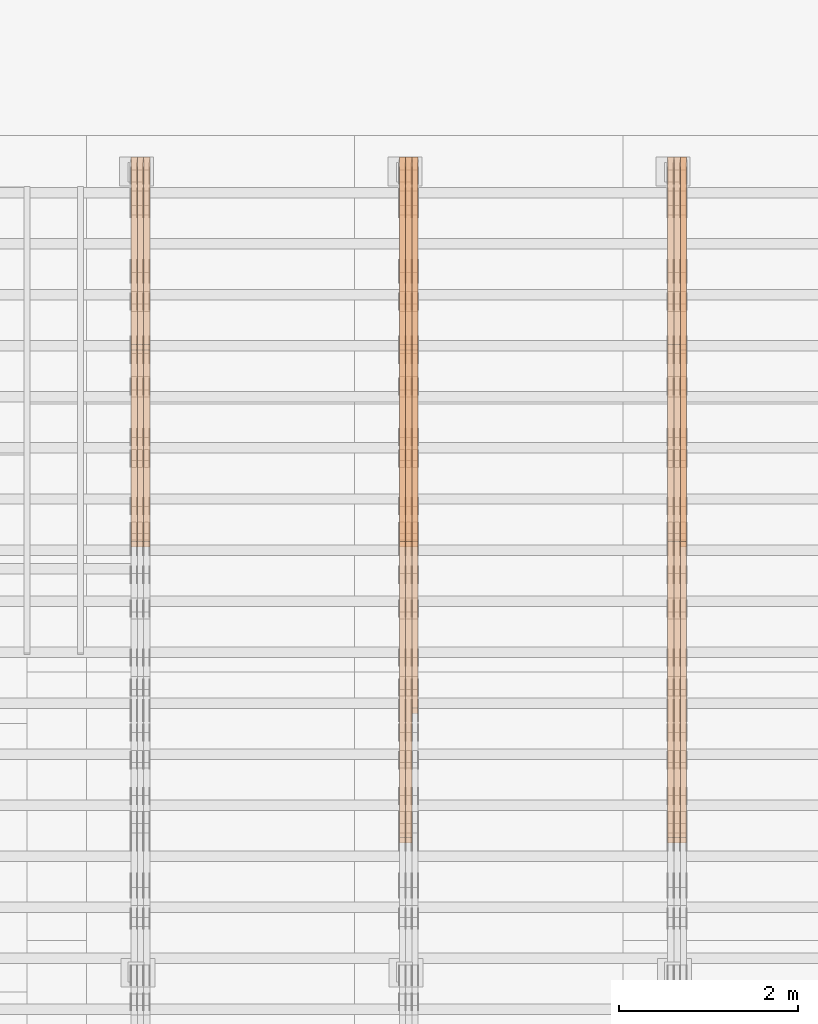
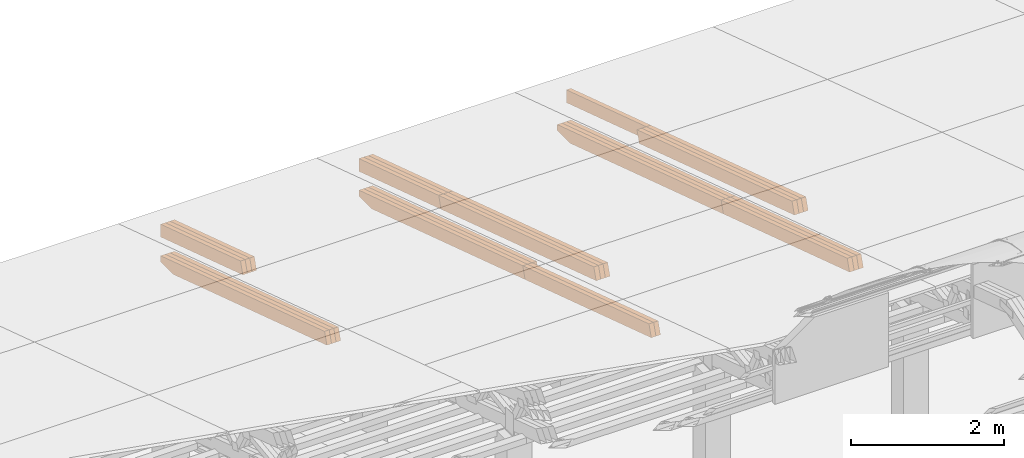
# One storey, part 21 of 385: 27 proxies.
"""IFC2X3 building model written with IfcOpenShell, lengths in millimetres."""

from ifc_helpers import new_model, entity, si_unit, converted_unit, derived_unit, direction, frame, origin, place, context, subcontext, project, spatial, polyline, outline, extrude, source, transform, mapped, material, type_object, type_shapes, element, save


model = new_model("IFC2X3")

# Units and contexts
model_context = context("Model", 3, precision=0.01, world=origin(), true_north=direction((6.12303176911189e-17, 1.0)))
body_context = subcontext(model_context, "Body", "Model", "MODEL_VIEW")
ifc_project = project(units=[si_unit("LENGTHUNIT", "METRE", prefix="MILLI"), si_unit("AREAUNIT", "SQUARE_METRE"), si_unit("VOLUMEUNIT", "CUBIC_METRE"), converted_unit("PLANEANGLEUNIT", "DEGREE", entity("IfcRatioMeasure", 0.0174532925199433), si_unit("PLANEANGLEUNIT", "RADIAN"), dimensions=[0, 0, 0, 0, 0, 0, 0]), si_unit("MASSUNIT", "GRAM", prefix="KILO"), derived_unit("MASSDENSITYUNIT", [(si_unit("MASSUNIT", "GRAM", prefix="KILO"), 1), (si_unit("LENGTHUNIT", "METRE"), -3)]), si_unit("TIMEUNIT", "SECOND"), si_unit("FREQUENCYUNIT", "HERTZ"), si_unit("THERMODYNAMICTEMPERATUREUNIT", "DEGREE_CELSIUS"), derived_unit("THERMALTRANSMITTANCEUNIT", [(si_unit("MASSUNIT", "GRAM", prefix="KILO"), 1), (si_unit("THERMODYNAMICTEMPERATUREUNIT", "KELVIN"), -1), (si_unit("TIMEUNIT", "SECOND"), -3)]), derived_unit("VOLUMETRICFLOWRATEUNIT", [(si_unit("LENGTHUNIT", "METRE"), 3), (si_unit("TIMEUNIT", "SECOND"), -1)]), si_unit("ELECTRICCURRENTUNIT", "AMPERE"), si_unit("ELECTRICVOLTAGEUNIT", "VOLT"), si_unit("POWERUNIT", "WATT"), si_unit("FORCEUNIT", "NEWTON", prefix="KILO"), si_unit("ILLUMINANCEUNIT", "LUX"), si_unit("LUMINOUSFLUXUNIT", "LUMEN"), si_unit("LUMINOUSINTENSITYUNIT", "CANDELA"), derived_unit("USERDEFINED", [(si_unit("MASSUNIT", "GRAM", prefix="KILO"), -1), (si_unit("LENGTHUNIT", "METRE"), -2), (si_unit("TIMEUNIT", "SECOND"), 3), (si_unit("LUMINOUSFLUXUNIT", "LUMEN"), 1)]), derived_unit("LINEARVELOCITYUNIT", [(si_unit("LENGTHUNIT", "METRE"), 1), (si_unit("TIMEUNIT", "SECOND"), -1)]), si_unit("PRESSUREUNIT", "PASCAL"), derived_unit("USERDEFINED", [(si_unit("LENGTHUNIT", "METRE"), -2), (si_unit("MASSUNIT", "GRAM", prefix="KILO"), 1), (si_unit("TIMEUNIT", "SECOND"), -2)])], contexts=[model_context])

# Site, building, storey
site_placement = place(None, origin())
site = spatial("IfcSite", under=ifc_project, at=site_placement, CompositionType="ELEMENT")
building_placement = place(site_placement, origin())
building = spatial("IfcBuilding", under=site, at=building_placement, CompositionType="ELEMENT")
storey_placement = place(building_placement, origin())
storey = spatial("IfcBuildingStorey", under=building, at=storey_placement, Name="Default", CompositionType="ELEMENT", Elevation=0.0)

# Proxies
ifc_material_1 = material(Name="IfcSurfaceStyle #180349")
building_element_proxy_type_1 = type_object("IfcBuildingElementProxyType", Name="T1-T2 180347", PredefinedType="NOTDEFINED", material=ifc_material_1)
shared_shape_1 = source(origin(), body_context, "Body", "SweptSolid", [
    extrude(outline(polyline([(-2137.04373183812, -97.5000250291418), (2137.04394104036, -97.5000250291418), (2137.04396402965, 97.5000250291418), (-2137.04417323189, 97.5000250291418), (-2137.04373183812, -97.5000250291418)])), frame((2137.04396402965, 97.5001541485632, 0.0), z_axis=(0.0, 0.0, 1.0), x_axis=(-1.0, 0.0, 0.0)), (0.0, 0.0, 1.0), 69.9999999999997),
])
type_shapes(building_element_proxy_type_1, [shared_shape_1])
proxy_1_placement = place(building_placement, frame((15385.0, 24344.7841397874, 1095.2368156767), z_axis=(-1.0, 0.0, 0.0), x_axis=(0.0, -0.951056516295154, 0.309016994374948)))
element("IfcBuildingElementProxy", 1, at=proxy_1_placement, inside=storey, type_object=building_element_proxy_type_1, material=ifc_material_1, Name="T1-T2", context=body_context, shape_type="MappedRepresentation", body=[
    mapped(shared_shape_1, transform((0.0, 0.0, 0.0), scale=1.0)),
])
ifc_material_2 = material(Name="IfcSurfaceStyle #180292")
building_element_proxy_type_2 = type_object("IfcBuildingElementProxyType", Name="T1-T2 180290", PredefinedType="NOTDEFINED", material=ifc_material_2)
shared_shape_2 = source(origin(), body_context, "Body", "SweptSolid", [
    extrude(outline(polyline([(-2137.04373183812, -97.5000250291418), (2137.04394104036, -97.5000250291418), (2137.04396402965, 97.5000250291418), (-2137.04417323189, 97.5000250291418), (-2137.04373183812, -97.5000250291418)])), frame((2137.04396402965, 97.5001541485632, 0.0), z_axis=(0.0, 0.0, 1.0), x_axis=(-1.0, 0.0, 0.0)), (0.0, 0.0, 1.0), 69.9999999999997),
])
type_shapes(building_element_proxy_type_2, [shared_shape_2])
proxy_2_placement = place(building_placement, frame((15315.0, 24344.7841397874, 1095.2368156767), z_axis=(-1.0, 0.0, 0.0), x_axis=(0.0, -0.951056516295154, 0.309016994374948)))
element("IfcBuildingElementProxy", 2, at=proxy_2_placement, inside=storey, type_object=building_element_proxy_type_2, material=ifc_material_2, Name="T1-T2", context=body_context, shape_type="MappedRepresentation", body=[
    mapped(shared_shape_2, transform((0.0, 0.0, 0.0), scale=1.0)),
])
ifc_material_3 = material(Name="IfcSurfaceStyle #180235")
building_element_proxy_type_3 = type_object("IfcBuildingElementProxyType", Name="T1-T2 180233", PredefinedType="NOTDEFINED", material=ifc_material_3)
shared_shape_3 = source(origin(), body_context, "Body", "SweptSolid", [
    extrude(outline(polyline([(-2137.04373183812, -97.5000250291418), (2137.04394104036, -97.5000250291418), (2137.04396402965, 97.5000250291418), (-2137.04417323189, 97.5000250291418), (-2137.04373183812, -97.5000250291418)])), frame((2137.04396402965, 97.5001541485632, 0.0), z_axis=(0.0, 0.0, 1.0), x_axis=(-1.0, 0.0, 0.0)), (0.0, 0.0, 1.0), 69.9999999999997),
])
type_shapes(building_element_proxy_type_3, [shared_shape_3])
proxy_3_placement = place(building_placement, frame((15245.0, 24344.7841397874, 1095.2368156767), z_axis=(-1.0, 0.0, 0.0), x_axis=(0.0, -0.951056516295154, 0.309016994374948)))
element("IfcBuildingElementProxy", 3, at=proxy_3_placement, inside=storey, type_object=building_element_proxy_type_3, material=ifc_material_3, Name="T1-T2", context=body_context, shape_type="MappedRepresentation", body=[
    mapped(shared_shape_3, transform((0.0, 0.0, 0.0), scale=1.0)),
])
ifc_material_4 = material(Name="IfcSurfaceStyle #180178")
building_element_proxy_type_4 = type_object("IfcBuildingElementProxyType", Name="T1-T3 180176", PredefinedType="NOTDEFINED", material=ifc_material_4)
shared_shape_4 = source(origin(), body_context, "Body", "SweptSolid", [
    extrude(outline(polyline([(-1117.22419189679, -97.5000115568039), (1085.54451125458, -97.5000115568039), (1148.90384954971, 97.5000115568039), (-1117.2241689075, 97.5000115568039), (-1117.22419189679, -97.5000115568039)])), frame((1148.90385201956, 97.5000191595882, 0.0), z_axis=(0.0, 0.0, 1.0), x_axis=(-1.0, 0.0, 0.0)), (0.0, 0.0, 1.0), 69.9999999999999),
])
type_shapes(building_element_proxy_type_4, [shared_shape_4])
proxy_4_placement = place(building_placement, frame((15385.0, 26500.0, 394.964866273674), z_axis=(-1.0, 0.0, 0.0), x_axis=(0.0, -0.951056516295154, 0.309016994374948)))
element("IfcBuildingElementProxy", 4, at=proxy_4_placement, inside=storey, type_object=building_element_proxy_type_4, material=ifc_material_4, Name="T1-T3", context=body_context, shape_type="MappedRepresentation", body=[
    mapped(shared_shape_4, transform((0.0, 0.0, 0.0), scale=1.0)),
])
ifc_material_5 = material(Name="IfcSurfaceStyle #178954")
building_element_proxy_type_5 = type_object("IfcBuildingElementProxyType", Name="T1-B2 178952", PredefinedType="NOTDEFINED", material=ifc_material_5)
shared_shape_5 = source(origin(), body_context, "Body", "SweptSolid", [
    extrude(outline(polyline([(-1738.61933402934, -97.4999466901035), (1738.6190788485, -97.4999466901035), (1738.6191018378, 97.4999466901035), (-1738.61884665697, 97.4999466901035), (-1738.61933402934, -97.4999466901035)])), frame((1738.6191018378, 97.4999528847471, 0.0), z_axis=(0.0, 0.0, 1.0), x_axis=(-1.0, 0.0, 0.0)), (0.0, 0.0, 1.0), 69.9999999999998),
])
type_shapes(building_element_proxy_type_5, [shared_shape_5])
proxy_5_placement = place(building_placement, frame((15385.0, 22140.4521465233, 1306.03026754604), z_axis=(-1.0, 0.0, 0.0), x_axis=(0.0, -0.951056516295124, 0.309016994375039)))
element("IfcBuildingElementProxy", 5, at=proxy_5_placement, inside=storey, type_object=building_element_proxy_type_5, material=ifc_material_5, Name="T1-B2", context=body_context, shape_type="MappedRepresentation", body=[
    mapped(shared_shape_5, transform((0.0, 0.0, 0.0), scale=1.0)),
])
ifc_material_6 = material(Name="IfcSurfaceStyle #178897")
building_element_proxy_type_6 = type_object("IfcBuildingElementProxyType", Name="T1-B2 178895", PredefinedType="NOTDEFINED", material=ifc_material_6)
shared_shape_6 = source(origin(), body_context, "Body", "SweptSolid", [
    extrude(outline(polyline([(-1738.61933402934, -97.4999466901035), (1738.6190788485, -97.4999466901035), (1738.6191018378, 97.4999466901035), (-1738.61884665697, 97.4999466901035), (-1738.61933402934, -97.4999466901035)])), frame((1738.6191018378, 97.4999528847471, 0.0), z_axis=(0.0, 0.0, 1.0), x_axis=(-1.0, 0.0, 0.0)), (0.0, 0.0, 1.0), 69.9999999999998),
])
type_shapes(building_element_proxy_type_6, [shared_shape_6])
proxy_6_placement = place(building_placement, frame((15315.0, 22140.4521465233, 1306.03026754604), z_axis=(-1.0, 0.0, 0.0), x_axis=(0.0, -0.951056516295124, 0.309016994375039)))
element("IfcBuildingElementProxy", 6, at=proxy_6_placement, inside=storey, type_object=building_element_proxy_type_6, material=ifc_material_6, Name="T1-B2", context=body_context, shape_type="MappedRepresentation", body=[
    mapped(shared_shape_6, transform((0.0, 0.0, 0.0), scale=1.0)),
])
ifc_material_7 = material(Name="IfcSurfaceStyle #178840")
building_element_proxy_type_7 = type_object("IfcBuildingElementProxyType", Name="T1-B2 178838", PredefinedType="NOTDEFINED", material=ifc_material_7)
shared_shape_7 = source(origin(), body_context, "Body", "SweptSolid", [
    extrude(outline(polyline([(-1738.61933402934, -97.4999466901035), (1738.6190788485, -97.4999466901035), (1738.6191018378, 97.4999466901035), (-1738.61884665697, 97.4999466901035), (-1738.61933402934, -97.4999466901035)])), frame((1738.6191018378, 97.4999528847471, 0.0), z_axis=(0.0, 0.0, 1.0), x_axis=(-1.0, 0.0, 0.0)), (0.0, 0.0, 1.0), 69.9999999999998),
])
type_shapes(building_element_proxy_type_7, [shared_shape_7])
proxy_7_placement = place(building_placement, frame((15245.0, 22140.4521465233, 1306.03026754604), z_axis=(-1.0, 0.0, 0.0), x_axis=(0.0, -0.951056516295124, 0.309016994375039)))
element("IfcBuildingElementProxy", 7, at=proxy_7_placement, inside=storey, type_object=building_element_proxy_type_7, material=ifc_material_7, Name="T1-B2", context=body_context, shape_type="MappedRepresentation", body=[
    mapped(shared_shape_7, transform((0.0, 0.0, 0.0), scale=1.0)),
])
ifc_material_8 = material(Name="IfcSurfaceStyle #178783")
building_element_proxy_type_8 = type_object("IfcBuildingElementProxyType", Name="T1-B1 178781", PredefinedType="NOTDEFINED", material=ifc_material_8)
shared_shape_8 = source(origin(), body_context, "Body", "SweptSolid", [
    extrude(outline(polyline([(-2659.34106034305, -95.9868650736445), (1861.19950396595, -95.9868650736445), (1890.42090463564, -6.05260867570997), (1567.0616890952, 99.0131694114995), (-2659.34103735375, 99.0131694114995), (-2659.34106034305, -95.9868650736445)])), frame((1890.42090463564, 99.013169411504, 0.0), z_axis=(0.0, 0.0, 1.0), x_axis=(-1.0, 0.0, 0.0)), (0.0, 0.0, 1.0), 69.9999999999997),
])
type_shapes(building_element_proxy_type_8, [shared_shape_8])
proxy_8_placement = place(building_placement, frame((15385.0, 26467.5328890438, -99.9234928894624), z_axis=(-1.0, 0.0, 0.0), x_axis=(0.0, -0.951056516295124, 0.309016994375039)))
element("IfcBuildingElementProxy", 8, at=proxy_8_placement, inside=storey, type_object=building_element_proxy_type_8, material=ifc_material_8, Name="T1-B1", context=body_context, shape_type="MappedRepresentation", body=[
    mapped(shared_shape_8, transform((0.0, 0.0, 0.0), scale=1.0)),
])
ifc_material_9 = material(Name="IfcSurfaceStyle #178717")
building_element_proxy_type_9 = type_object("IfcBuildingElementProxyType", Name="T1-B1 178715", PredefinedType="NOTDEFINED", material=ifc_material_9)
shared_shape_9 = source(origin(), body_context, "Body", "SweptSolid", [
    extrude(outline(polyline([(-2659.34106034305, -95.9868650736445), (1861.19950396595, -95.9868650736445), (1890.42090463564, -6.05260867570997), (1567.0616890952, 99.0131694114995), (-2659.34103735375, 99.0131694114995), (-2659.34106034305, -95.9868650736445)])), frame((1890.42090463564, 99.013169411504, 0.0), z_axis=(0.0, 0.0, 1.0), x_axis=(-1.0, 0.0, 0.0)), (0.0, 0.0, 1.0), 69.9999999999997),
])
type_shapes(building_element_proxy_type_9, [shared_shape_9])
proxy_9_placement = place(building_placement, frame((15315.0, 26467.5328890438, -99.9234928894624), z_axis=(-1.0, 0.0, 0.0), x_axis=(0.0, -0.951056516295124, 0.309016994375039)))
element("IfcBuildingElementProxy", 9, at=proxy_9_placement, inside=storey, type_object=building_element_proxy_type_9, material=ifc_material_9, Name="T1-B1", context=body_context, shape_type="MappedRepresentation", body=[
    mapped(shared_shape_9, transform((0.0, 0.0, 0.0), scale=1.0)),
])
ifc_material_10 = material(Name="IfcSurfaceStyle #178651")
building_element_proxy_type_10 = type_object("IfcBuildingElementProxyType", Name="T1-B1 178649", PredefinedType="NOTDEFINED", material=ifc_material_10)
shared_shape_10 = source(origin(), body_context, "Body", "SweptSolid", [
    extrude(outline(polyline([(-2659.34106034305, -95.9868650736445), (1861.19950396595, -95.9868650736445), (1890.42090463564, -6.05260867570997), (1567.0616890952, 99.0131694114995), (-2659.34103735375, 99.0131694114995), (-2659.34106034305, -95.9868650736445)])), frame((1890.42090463564, 99.013169411504, 0.0), z_axis=(0.0, 0.0, 1.0), x_axis=(-1.0, 0.0, 0.0)), (0.0, 0.0, 1.0), 69.9999999999997),
])
type_shapes(building_element_proxy_type_10, [shared_shape_10])
proxy_10_placement = place(building_placement, frame((15245.0, 26467.5328890438, -99.9234928894624), z_axis=(-1.0, 0.0, 0.0), x_axis=(0.0, -0.951056516295124, 0.309016994375039)))
element("IfcBuildingElementProxy", 10, at=proxy_10_placement, inside=storey, type_object=building_element_proxy_type_10, material=ifc_material_10, Name="T1-B1", context=body_context, shape_type="MappedRepresentation", body=[
    mapped(shared_shape_10, transform((0.0, 0.0, 0.0), scale=1.0)),
])
ifc_material_11 = material(Name="IfcSurfaceStyle #145917")
building_element_proxy_type_11 = type_object("IfcBuildingElementProxyType", Name="T1-T2 145915", PredefinedType="NOTDEFINED", material=ifc_material_11)
shared_shape_11 = source(origin(), body_context, "Body", "SweptSolid", [
    extrude(outline(polyline([(-2137.04373183812, -97.5000250291418), (2137.04394104036, -97.5000250291418), (2137.04396402965, 97.5000250291418), (-2137.04417323189, 97.5000250291418), (-2137.04373183812, -97.5000250291418)])), frame((2137.04396402965, 97.5001541485632, 0.0), z_axis=(0.0, 0.0, 1.0), x_axis=(-1.0, 0.0, 0.0)), (0.0, 0.0, 1.0), 69.9999999999997),
])
type_shapes(building_element_proxy_type_11, [shared_shape_11])
proxy_11_placement = place(building_placement, frame((12385.0, 24344.7841397874, 1095.2368156767), z_axis=(-1.0, 0.0, 0.0), x_axis=(0.0, -0.951056516295154, 0.309016994374948)))
element("IfcBuildingElementProxy", 11, at=proxy_11_placement, inside=storey, type_object=building_element_proxy_type_11, material=ifc_material_11, Name="T1-T2", context=body_context, shape_type="MappedRepresentation", body=[
    mapped(shared_shape_11, transform((0.0, 0.0, 0.0), scale=1.0)),
])
ifc_material_12 = material(Name="IfcSurfaceStyle #145860")
building_element_proxy_type_12 = type_object("IfcBuildingElementProxyType", Name="T1-T2 145858", PredefinedType="NOTDEFINED", material=ifc_material_12)
shared_shape_12 = source(origin(), body_context, "Body", "SweptSolid", [
    extrude(outline(polyline([(-2137.04373183812, -97.5000250291418), (2137.04394104036, -97.5000250291418), (2137.04396402965, 97.5000250291418), (-2137.04417323189, 97.5000250291418), (-2137.04373183812, -97.5000250291418)])), frame((2137.04396402965, 97.5001541485632, 0.0), z_axis=(0.0, 0.0, 1.0), x_axis=(-1.0, 0.0, 0.0)), (0.0, 0.0, 1.0), 69.9999999999997),
])
type_shapes(building_element_proxy_type_12, [shared_shape_12])
proxy_12_placement = place(building_placement, frame((12315.0, 24344.7841397874, 1095.2368156767), z_axis=(-1.0, 0.0, 0.0), x_axis=(0.0, -0.951056516295154, 0.309016994374948)))
element("IfcBuildingElementProxy", 12, at=proxy_12_placement, inside=storey, type_object=building_element_proxy_type_12, material=ifc_material_12, Name="T1-T2", context=body_context, shape_type="MappedRepresentation", body=[
    mapped(shared_shape_12, transform((0.0, 0.0, 0.0), scale=1.0)),
])
ifc_material_13 = material(Name="IfcSurfaceStyle #145803")
building_element_proxy_type_13 = type_object("IfcBuildingElementProxyType", Name="T1-T2 145801", PredefinedType="NOTDEFINED", material=ifc_material_13)
shared_shape_13 = source(origin(), body_context, "Body", "SweptSolid", [
    extrude(outline(polyline([(-2137.04373183812, -97.5000250291418), (2137.04394104036, -97.5000250291418), (2137.04396402965, 97.5000250291418), (-2137.04417323189, 97.5000250291418), (-2137.04373183812, -97.5000250291418)])), frame((2137.04396402965, 97.5001541485632, 0.0), z_axis=(0.0, 0.0, 1.0), x_axis=(-1.0, 0.0, 0.0)), (0.0, 0.0, 1.0), 69.9999999999997),
])
type_shapes(building_element_proxy_type_13, [shared_shape_13])
proxy_13_placement = place(building_placement, frame((12245.0, 24344.7841397874, 1095.2368156767), z_axis=(-1.0, 0.0, 0.0), x_axis=(0.0, -0.951056516295154, 0.309016994374948)))
element("IfcBuildingElementProxy", 13, at=proxy_13_placement, inside=storey, type_object=building_element_proxy_type_13, material=ifc_material_13, Name="T1-T2", context=body_context, shape_type="MappedRepresentation", body=[
    mapped(shared_shape_13, transform((0.0, 0.0, 0.0), scale=1.0)),
])
ifc_material_14 = material(Name="IfcSurfaceStyle #145746")
building_element_proxy_type_14 = type_object("IfcBuildingElementProxyType", Name="T1-T3 145744", PredefinedType="NOTDEFINED", material=ifc_material_14)
shared_shape_14 = source(origin(), body_context, "Body", "SweptSolid", [
    extrude(outline(polyline([(-1117.22419189679, -97.5000115568039), (1085.54451125458, -97.5000115568039), (1148.90384954971, 97.5000115568039), (-1117.2241689075, 97.5000115568039), (-1117.22419189679, -97.5000115568039)])), frame((1148.90385201956, 97.5000191595882, 0.0), z_axis=(0.0, 0.0, 1.0), x_axis=(-1.0, 0.0, 0.0)), (0.0, 0.0, 1.0), 69.9999999999999),
])
type_shapes(building_element_proxy_type_14, [shared_shape_14])
proxy_14_placement = place(building_placement, frame((12385.0, 26500.0, 394.964866273674), z_axis=(-1.0, 0.0, 0.0), x_axis=(0.0, -0.951056516295154, 0.309016994374948)))
element("IfcBuildingElementProxy", 14, at=proxy_14_placement, inside=storey, type_object=building_element_proxy_type_14, material=ifc_material_14, Name="T1-T3", context=body_context, shape_type="MappedRepresentation", body=[
    mapped(shared_shape_14, transform((0.0, 0.0, 0.0), scale=1.0)),
])
ifc_material_15 = material(Name="IfcSurfaceStyle #145689")
building_element_proxy_type_15 = type_object("IfcBuildingElementProxyType", Name="T1-T3 145687", PredefinedType="NOTDEFINED", material=ifc_material_15)
shared_shape_15 = source(origin(), body_context, "Body", "SweptSolid", [
    extrude(outline(polyline([(-1117.22419189679, -97.5000115568039), (1085.54451125458, -97.5000115568039), (1148.90384954971, 97.5000115568039), (-1117.2241689075, 97.5000115568039), (-1117.22419189679, -97.5000115568039)])), frame((1148.90385201956, 97.5000191595882, 0.0), z_axis=(0.0, 0.0, 1.0), x_axis=(-1.0, 0.0, 0.0)), (0.0, 0.0, 1.0), 69.9999999999999),
])
type_shapes(building_element_proxy_type_15, [shared_shape_15])
proxy_15_placement = place(building_placement, frame((12315.0, 26500.0, 394.964866273674), z_axis=(-1.0, 0.0, 0.0), x_axis=(0.0, -0.951056516295154, 0.309016994374948)))
element("IfcBuildingElementProxy", 15, at=proxy_15_placement, inside=storey, type_object=building_element_proxy_type_15, material=ifc_material_15, Name="T1-T3", context=body_context, shape_type="MappedRepresentation", body=[
    mapped(shared_shape_15, transform((0.0, 0.0, 0.0), scale=1.0)),
])
ifc_material_16 = material(Name="IfcSurfaceStyle #145632")
building_element_proxy_type_16 = type_object("IfcBuildingElementProxyType", Name="T1-T3 145630", PredefinedType="NOTDEFINED", material=ifc_material_16)
shared_shape_16 = source(origin(), body_context, "Body", "SweptSolid", [
    extrude(outline(polyline([(-1117.22419189679, -97.5000115568039), (1085.54451125458, -97.5000115568039), (1148.90384954971, 97.5000115568039), (-1117.2241689075, 97.5000115568039), (-1117.22419189679, -97.5000115568039)])), frame((1148.90385201956, 97.5000191595882, 0.0), z_axis=(0.0, 0.0, 1.0), x_axis=(-1.0, 0.0, 0.0)), (0.0, 0.0, 1.0), 69.9999999999999),
])
type_shapes(building_element_proxy_type_16, [shared_shape_16])
proxy_16_placement = place(building_placement, frame((12245.0, 26500.0, 394.964866273674), z_axis=(-1.0, 0.0, 0.0), x_axis=(0.0, -0.951056516295154, 0.309016994374948)))
element("IfcBuildingElementProxy", 16, at=proxy_16_placement, inside=storey, type_object=building_element_proxy_type_16, material=ifc_material_16, Name="T1-T3", context=body_context, shape_type="MappedRepresentation", body=[
    mapped(shared_shape_16, transform((0.0, 0.0, 0.0), scale=1.0)),
])
ifc_material_17 = material(Name="IfcSurfaceStyle #144465")
building_element_proxy_type_17 = type_object("IfcBuildingElementProxyType", Name="T1-B2 144463", PredefinedType="NOTDEFINED", material=ifc_material_17)
shared_shape_17 = source(origin(), body_context, "Body", "SweptSolid", [
    extrude(outline(polyline([(-1738.61933402934, -97.4999466901035), (1738.6190788485, -97.4999466901035), (1738.6191018378, 97.4999466901035), (-1738.61884665697, 97.4999466901035), (-1738.61933402934, -97.4999466901035)])), frame((1738.6191018378, 97.4999528847471, 0.0), z_axis=(0.0, 0.0, 1.0), x_axis=(-1.0, 0.0, 0.0)), (0.0, 0.0, 1.0), 69.9999999999998),
])
type_shapes(building_element_proxy_type_17, [shared_shape_17])
proxy_17_placement = place(building_placement, frame((12315.0, 22140.4521465233, 1306.03026754604), z_axis=(-1.0, 0.0, 0.0), x_axis=(0.0, -0.951056516295124, 0.309016994375039)))
element("IfcBuildingElementProxy", 17, at=proxy_17_placement, inside=storey, type_object=building_element_proxy_type_17, material=ifc_material_17, Name="T1-B2", context=body_context, shape_type="MappedRepresentation", body=[
    mapped(shared_shape_17, transform((0.0, 0.0, 0.0), scale=1.0)),
])
ifc_material_18 = material(Name="IfcSurfaceStyle #144408")
building_element_proxy_type_18 = type_object("IfcBuildingElementProxyType", Name="T1-B2 144406", PredefinedType="NOTDEFINED", material=ifc_material_18)
shared_shape_18 = source(origin(), body_context, "Body", "SweptSolid", [
    extrude(outline(polyline([(-1738.61933402934, -97.4999466901035), (1738.6190788485, -97.4999466901035), (1738.6191018378, 97.4999466901035), (-1738.61884665697, 97.4999466901035), (-1738.61933402934, -97.4999466901035)])), frame((1738.6191018378, 97.4999528847471, 0.0), z_axis=(0.0, 0.0, 1.0), x_axis=(-1.0, 0.0, 0.0)), (0.0, 0.0, 1.0), 69.9999999999998),
])
type_shapes(building_element_proxy_type_18, [shared_shape_18])
proxy_18_placement = place(building_placement, frame((12245.0, 22140.4521465233, 1306.03026754604), z_axis=(-1.0, 0.0, 0.0), x_axis=(0.0, -0.951056516295124, 0.309016994375039)))
element("IfcBuildingElementProxy", 18, at=proxy_18_placement, inside=storey, type_object=building_element_proxy_type_18, material=ifc_material_18, Name="T1-B2", context=body_context, shape_type="MappedRepresentation", body=[
    mapped(shared_shape_18, transform((0.0, 0.0, 0.0), scale=1.0)),
])
ifc_material_19 = material(Name="IfcSurfaceStyle #144351")
building_element_proxy_type_19 = type_object("IfcBuildingElementProxyType", Name="T1-B1 144349", PredefinedType="NOTDEFINED", material=ifc_material_19)
shared_shape_19 = source(origin(), body_context, "Body", "SweptSolid", [
    extrude(outline(polyline([(-2659.34106034305, -95.9868650736445), (1861.19950396595, -95.9868650736445), (1890.42090463564, -6.05260867570997), (1567.0616890952, 99.0131694114995), (-2659.34103735375, 99.0131694114995), (-2659.34106034305, -95.9868650736445)])), frame((1890.42090463564, 99.013169411504, 0.0), z_axis=(0.0, 0.0, 1.0), x_axis=(-1.0, 0.0, 0.0)), (0.0, 0.0, 1.0), 69.9999999999997),
])
type_shapes(building_element_proxy_type_19, [shared_shape_19])
proxy_19_placement = place(building_placement, frame((12385.0, 26467.5328890438, -99.9234928894624), z_axis=(-1.0, 0.0, 0.0), x_axis=(0.0, -0.951056516295124, 0.309016994375039)))
element("IfcBuildingElementProxy", 19, at=proxy_19_placement, inside=storey, type_object=building_element_proxy_type_19, material=ifc_material_19, Name="T1-B1", context=body_context, shape_type="MappedRepresentation", body=[
    mapped(shared_shape_19, transform((0.0, 0.0, 0.0), scale=1.0)),
])
ifc_material_20 = material(Name="IfcSurfaceStyle #144285")
building_element_proxy_type_20 = type_object("IfcBuildingElementProxyType", Name="T1-B1 144283", PredefinedType="NOTDEFINED", material=ifc_material_20)
shared_shape_20 = source(origin(), body_context, "Body", "SweptSolid", [
    extrude(outline(polyline([(-2659.34106034305, -95.9868650736445), (1861.19950396595, -95.9868650736445), (1890.42090463564, -6.05260867570997), (1567.0616890952, 99.0131694114995), (-2659.34103735375, 99.0131694114995), (-2659.34106034305, -95.9868650736445)])), frame((1890.42090463564, 99.013169411504, 0.0), z_axis=(0.0, 0.0, 1.0), x_axis=(-1.0, 0.0, 0.0)), (0.0, 0.0, 1.0), 69.9999999999997),
])
type_shapes(building_element_proxy_type_20, [shared_shape_20])
proxy_20_placement = place(building_placement, frame((12315.0, 26467.5328890438, -99.9234928894624), z_axis=(-1.0, 0.0, 0.0), x_axis=(0.0, -0.951056516295124, 0.309016994375039)))
element("IfcBuildingElementProxy", 20, at=proxy_20_placement, inside=storey, type_object=building_element_proxy_type_20, material=ifc_material_20, Name="T1-B1", context=body_context, shape_type="MappedRepresentation", body=[
    mapped(shared_shape_20, transform((0.0, 0.0, 0.0), scale=1.0)),
])
ifc_material_21 = material(Name="IfcSurfaceStyle #144219")
building_element_proxy_type_21 = type_object("IfcBuildingElementProxyType", Name="T1-B1 144217", PredefinedType="NOTDEFINED", material=ifc_material_21)
shared_shape_21 = source(origin(), body_context, "Body", "SweptSolid", [
    extrude(outline(polyline([(-2659.34106034305, -95.9868650736445), (1861.19950396595, -95.9868650736445), (1890.42090463564, -6.05260867570997), (1567.0616890952, 99.0131694114995), (-2659.34103735375, 99.0131694114995), (-2659.34106034305, -95.9868650736445)])), frame((1890.42090463564, 99.013169411504, 0.0), z_axis=(0.0, 0.0, 1.0), x_axis=(-1.0, 0.0, 0.0)), (0.0, 0.0, 1.0), 69.9999999999997),
])
type_shapes(building_element_proxy_type_21, [shared_shape_21])
proxy_21_placement = place(building_placement, frame((12245.0, 26467.5328890438, -99.9234928894624), z_axis=(-1.0, 0.0, 0.0), x_axis=(0.0, -0.951056516295124, 0.309016994375039)))
element("IfcBuildingElementProxy", 21, at=proxy_21_placement, inside=storey, type_object=building_element_proxy_type_21, material=ifc_material_21, Name="T1-B1", context=body_context, shape_type="MappedRepresentation", body=[
    mapped(shared_shape_21, transform((0.0, 0.0, 0.0), scale=1.0)),
])
ifc_material_22 = material(Name="IfcSurfaceStyle #111314")
building_element_proxy_type_22 = type_object("IfcBuildingElementProxyType", Name="T1-T3 111312", PredefinedType="NOTDEFINED", material=ifc_material_22)
shared_shape_22 = source(origin(), body_context, "Body", "SweptSolid", [
    extrude(outline(polyline([(-1117.22419189679, -97.5000115568039), (1085.54451125458, -97.5000115568039), (1148.90384954971, 97.5000115568039), (-1117.2241689075, 97.5000115568039), (-1117.22419189679, -97.5000115568039)])), frame((1148.90385201956, 97.5000191595882, 0.0), z_axis=(0.0, 0.0, 1.0), x_axis=(-1.0, 0.0, 0.0)), (0.0, 0.0, 1.0), 69.9999999999999),
])
type_shapes(building_element_proxy_type_22, [shared_shape_22])
proxy_22_placement = place(building_placement, frame((9385.0, 26500.0, 394.964866273674), z_axis=(-1.0, 0.0, 0.0), x_axis=(0.0, -0.951056516295154, 0.309016994374948)))
element("IfcBuildingElementProxy", 22, at=proxy_22_placement, inside=storey, type_object=building_element_proxy_type_22, material=ifc_material_22, Name="T1-T3", context=body_context, shape_type="MappedRepresentation", body=[
    mapped(shared_shape_22, transform((0.0, 0.0, 0.0), scale=1.0)),
])
ifc_material_23 = material(Name="IfcSurfaceStyle #111257")
building_element_proxy_type_23 = type_object("IfcBuildingElementProxyType", Name="T1-T3 111255", PredefinedType="NOTDEFINED", material=ifc_material_23)
shared_shape_23 = source(origin(), body_context, "Body", "SweptSolid", [
    extrude(outline(polyline([(-1117.22419189679, -97.5000115568039), (1085.54451125458, -97.5000115568039), (1148.90384954971, 97.5000115568039), (-1117.2241689075, 97.5000115568039), (-1117.22419189679, -97.5000115568039)])), frame((1148.90385201956, 97.5000191595882, 0.0), z_axis=(0.0, 0.0, 1.0), x_axis=(-1.0, 0.0, 0.0)), (0.0, 0.0, 1.0), 69.9999999999999),
])
type_shapes(building_element_proxy_type_23, [shared_shape_23])
proxy_23_placement = place(building_placement, frame((9315.0, 26500.0, 394.964866273674), z_axis=(-1.0, 0.0, 0.0), x_axis=(0.0, -0.951056516295154, 0.309016994374948)))
element("IfcBuildingElementProxy", 23, at=proxy_23_placement, inside=storey, type_object=building_element_proxy_type_23, material=ifc_material_23, Name="T1-T3", context=body_context, shape_type="MappedRepresentation", body=[
    mapped(shared_shape_23, transform((0.0, 0.0, 0.0), scale=1.0)),
])
ifc_material_24 = material(Name="IfcSurfaceStyle #111200")
building_element_proxy_type_24 = type_object("IfcBuildingElementProxyType", Name="T1-T3 111198", PredefinedType="NOTDEFINED", material=ifc_material_24)
shared_shape_24 = source(origin(), body_context, "Body", "SweptSolid", [
    extrude(outline(polyline([(-1117.22419189679, -97.5000115568039), (1085.54451125458, -97.5000115568039), (1148.90384954971, 97.5000115568039), (-1117.2241689075, 97.5000115568039), (-1117.22419189679, -97.5000115568039)])), frame((1148.90385201956, 97.5000191595882, 0.0), z_axis=(0.0, 0.0, 1.0), x_axis=(-1.0, 0.0, 0.0)), (0.0, 0.0, 1.0), 69.9999999999999),
])
type_shapes(building_element_proxy_type_24, [shared_shape_24])
proxy_24_placement = place(building_placement, frame((9245.0, 26500.0, 394.964866273674), z_axis=(-1.0, 0.0, 0.0), x_axis=(0.0, -0.951056516295154, 0.309016994374948)))
element("IfcBuildingElementProxy", 24, at=proxy_24_placement, inside=storey, type_object=building_element_proxy_type_24, material=ifc_material_24, Name="T1-T3", context=body_context, shape_type="MappedRepresentation", body=[
    mapped(shared_shape_24, transform((0.0, 0.0, 0.0), scale=1.0)),
])
ifc_material_25 = material(Name="IfcSurfaceStyle #109919")
building_element_proxy_type_25 = type_object("IfcBuildingElementProxyType", Name="T1-B1 109917", PredefinedType="NOTDEFINED", material=ifc_material_25)
shared_shape_25 = source(origin(), body_context, "Body", "SweptSolid", [
    extrude(outline(polyline([(-2659.34106034305, -95.9868650736445), (1861.19950396595, -95.9868650736445), (1890.42090463564, -6.05260867570997), (1567.0616890952, 99.0131694114995), (-2659.34103735375, 99.0131694114995), (-2659.34106034305, -95.9868650736445)])), frame((1890.42090463564, 99.013169411504, 0.0), z_axis=(0.0, 0.0, 1.0), x_axis=(-1.0, 0.0, 0.0)), (0.0, 0.0, 1.0), 69.9999999999997),
])
type_shapes(building_element_proxy_type_25, [shared_shape_25])
proxy_25_placement = place(building_placement, frame((9385.0, 26467.5328890438, -99.9234928894624), z_axis=(-1.0, 0.0, 0.0), x_axis=(0.0, -0.951056516295124, 0.309016994375039)))
element("IfcBuildingElementProxy", 25, at=proxy_25_placement, inside=storey, type_object=building_element_proxy_type_25, material=ifc_material_25, Name="T1-B1", context=body_context, shape_type="MappedRepresentation", body=[
    mapped(shared_shape_25, transform((0.0, 0.0, 0.0), scale=1.0)),
])
ifc_material_26 = material(Name="IfcSurfaceStyle #109853")
building_element_proxy_type_26 = type_object("IfcBuildingElementProxyType", Name="T1-B1 109851", PredefinedType="NOTDEFINED", material=ifc_material_26)
shared_shape_26 = source(origin(), body_context, "Body", "SweptSolid", [
    extrude(outline(polyline([(-2659.34106034305, -95.9868650736445), (1861.19950396595, -95.9868650736445), (1890.42090463564, -6.05260867570997), (1567.0616890952, 99.0131694114995), (-2659.34103735375, 99.0131694114995), (-2659.34106034305, -95.9868650736445)])), frame((1890.42090463564, 99.013169411504, 0.0), z_axis=(0.0, 0.0, 1.0), x_axis=(-1.0, 0.0, 0.0)), (0.0, 0.0, 1.0), 69.9999999999997),
])
type_shapes(building_element_proxy_type_26, [shared_shape_26])
proxy_26_placement = place(building_placement, frame((9315.0, 26467.5328890438, -99.9234928894624), z_axis=(-1.0, 0.0, 0.0), x_axis=(0.0, -0.951056516295124, 0.309016994375039)))
element("IfcBuildingElementProxy", 26, at=proxy_26_placement, inside=storey, type_object=building_element_proxy_type_26, material=ifc_material_26, Name="T1-B1", context=body_context, shape_type="MappedRepresentation", body=[
    mapped(shared_shape_26, transform((0.0, 0.0, 0.0), scale=1.0)),
])
ifc_material_27 = material(Name="IfcSurfaceStyle #109787")
building_element_proxy_type_27 = type_object("IfcBuildingElementProxyType", Name="T1-B1 109785", PredefinedType="NOTDEFINED", material=ifc_material_27)
shared_shape_27 = source(origin(), body_context, "Body", "SweptSolid", [
    extrude(outline(polyline([(-2659.34106034305, -95.9868650736445), (1861.19950396595, -95.9868650736445), (1890.42090463564, -6.05260867570997), (1567.0616890952, 99.0131694114995), (-2659.34103735375, 99.0131694114995), (-2659.34106034305, -95.9868650736445)])), frame((1890.42090463564, 99.013169411504, 0.0), z_axis=(0.0, 0.0, 1.0), x_axis=(-1.0, 0.0, 0.0)), (0.0, 0.0, 1.0), 69.9999999999997),
])
type_shapes(building_element_proxy_type_27, [shared_shape_27])
proxy_27_placement = place(building_placement, frame((9245.0, 26467.5328890438, -99.9234928894624), z_axis=(-1.0, 0.0, 0.0), x_axis=(0.0, -0.951056516295124, 0.309016994375039)))
element("IfcBuildingElementProxy", 27, at=proxy_27_placement, inside=storey, type_object=building_element_proxy_type_27, material=ifc_material_27, Name="T1-B1", context=body_context, shape_type="MappedRepresentation", body=[
    mapped(shared_shape_27, transform((0.0, 0.0, 0.0), scale=1.0)),
])

save(model, "model.ifc")
